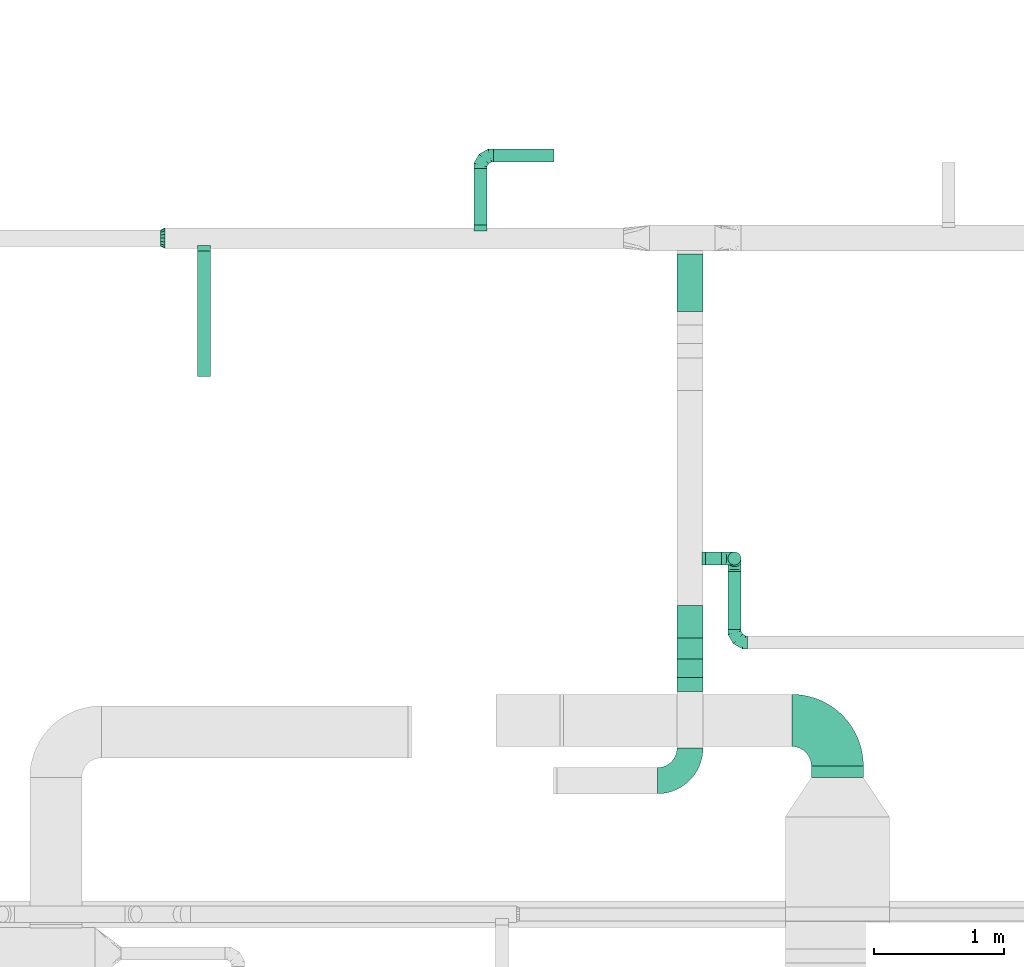
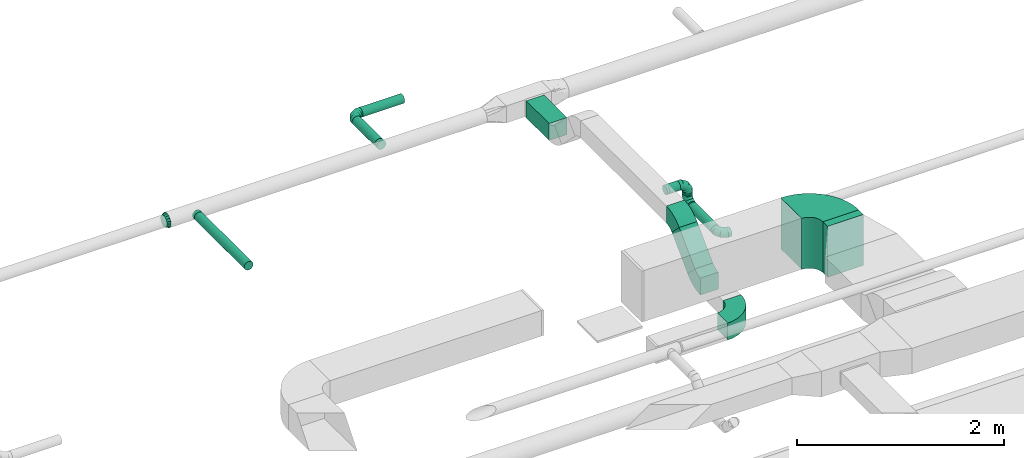
# One storey, part 40 of 60: 12 flow fittings, 9 flow segments.
"""IFC2X3 building model written with IfcOpenShell, lengths in millimetres."""

from ifc_helpers import new_model, entity, si_unit, converted_unit, derived_unit, direction, frame, frame_2d, origin, origin_2d_with_axis, place, context, subcontext, project, spatial, polyline, circle_curve, parameter, trimmed, segment, composite_curve, rectangle, circle, outline, extrude, faceted_brep, source, transform, mapped, material, type_object, type_shapes, element, save


model = new_model("IFC2X3")

# Units and contexts
model_context = context("Model", 3, precision=0.01, world=origin(), true_north=direction((6.12303176911189e-17, 1.0)))
body_context = subcontext(model_context, "Body", "Model", "MODEL_VIEW")
ifc_project = project(units=[si_unit("LENGTHUNIT", "METRE", prefix="MILLI"), si_unit("AREAUNIT", "SQUARE_METRE"), si_unit("VOLUMEUNIT", "CUBIC_METRE"), converted_unit("PLANEANGLEUNIT", "DEGREE", entity("IfcRatioMeasure", 0.0174532925199433), si_unit("PLANEANGLEUNIT", "RADIAN"), dimensions=[0, 0, 0, 0, 0, 0, 0]), si_unit("MASSUNIT", "GRAM", prefix="KILO"), derived_unit("MASSDENSITYUNIT", [(si_unit("MASSUNIT", "GRAM", prefix="KILO"), 1), (si_unit("LENGTHUNIT", "METRE"), -3)]), derived_unit("MOMENTOFINERTIAUNIT", [(si_unit("LENGTHUNIT", "METRE"), 4)]), si_unit("TIMEUNIT", "SECOND"), si_unit("FREQUENCYUNIT", "HERTZ"), si_unit("THERMODYNAMICTEMPERATUREUNIT", "DEGREE_CELSIUS"), derived_unit("THERMALTRANSMITTANCEUNIT", [(si_unit("MASSUNIT", "GRAM", prefix="KILO"), 1), (si_unit("THERMODYNAMICTEMPERATUREUNIT", "KELVIN"), -1), (si_unit("TIMEUNIT", "SECOND"), -3)]), derived_unit("VOLUMETRICFLOWRATEUNIT", [(si_unit("LENGTHUNIT", "METRE"), 3), (si_unit("TIMEUNIT", "SECOND"), -1)]), derived_unit("MASSFLOWRATEUNIT", [(si_unit("MASSUNIT", "GRAM", prefix="KILO"), 1), (si_unit("TIMEUNIT", "SECOND"), -1)]), derived_unit("ROTATIONALFREQUENCYUNIT", [(si_unit("TIMEUNIT", "SECOND"), -1)]), si_unit("ELECTRICCURRENTUNIT", "AMPERE"), si_unit("ELECTRICVOLTAGEUNIT", "VOLT"), si_unit("POWERUNIT", "WATT"), si_unit("FORCEUNIT", "NEWTON", prefix="KILO"), si_unit("ILLUMINANCEUNIT", "LUX"), si_unit("LUMINOUSFLUXUNIT", "LUMEN"), si_unit("LUMINOUSINTENSITYUNIT", "CANDELA"), derived_unit("USERDEFINED", [(si_unit("MASSUNIT", "GRAM", prefix="KILO"), -1), (si_unit("LENGTHUNIT", "METRE"), -2), (si_unit("TIMEUNIT", "SECOND"), 3), (si_unit("LUMINOUSFLUXUNIT", "LUMEN"), 1)]), derived_unit("LINEARVELOCITYUNIT", [(si_unit("LENGTHUNIT", "METRE"), 1), (si_unit("TIMEUNIT", "SECOND"), -1)]), si_unit("PRESSUREUNIT", "PASCAL"), derived_unit("USERDEFINED", [(si_unit("LENGTHUNIT", "METRE"), -2), (si_unit("MASSUNIT", "GRAM", prefix="KILO"), 1), (si_unit("TIMEUNIT", "SECOND"), -2)]), derived_unit("LINEARFORCEUNIT", [(si_unit("MASSUNIT", "GRAM", prefix="KILO"), 1), (si_unit("LENGTHUNIT", "METRE"), 1), (si_unit("TIMEUNIT", "SECOND"), -2), (si_unit("LENGTHUNIT", "METRE"), -1)]), derived_unit("PLANARFORCEUNIT", [(si_unit("MASSUNIT", "GRAM", prefix="KILO"), 1), (si_unit("LENGTHUNIT", "METRE"), 1), (si_unit("TIMEUNIT", "SECOND"), -2), (si_unit("LENGTHUNIT", "METRE"), -2)])], contexts=[model_context])

# Site, building, storey
site_placement = place(None, origin())
site = spatial("IfcSite", under=ifc_project, at=site_placement, CompositionType="ELEMENT")
building_placement = place(site_placement, origin())
building = spatial("IfcBuilding", under=site, at=building_placement, CompositionType="ELEMENT")
storey_placement = place(building_placement, frame((0.0, 0.0, 19800.0)))
storey = spatial("IfcBuildingStorey", under=building, at=storey_placement, CompositionType="ELEMENT", Elevation=19800.0)

# Flow segments
duct_segment_type_1 = type_object("IfcDuctSegmentType", PredefinedType="NOTDEFINED")
flow_segment_1_placement = place(storey_placement, frame((54721.8, 11333.78, 3050.0)))
element("IfcFlowSegment", 1, at=flow_segment_1_placement, inside=storey, type_object=duct_segment_type_1, context=body_context, shape_type="SweptSolid", body=[
    extrude(rectangle(XDim=90.0000000001701, YDim=399.999999999996, at=origin_2d_with_axis()), frame((200.0, 45.0, 0.0), z_axis=(0.0, 0.0, 1.0), x_axis=(0.0, -1.0, 0.0)), (0.0, 0.0, 1.0), 600.000000000002),
])
flow_segment_2_placement = place(storey_placement, frame((53690.46, 14914.29, 2850.0)))
element("IfcFlowSegment", 2, at=flow_segment_2_placement, inside=storey, type_object=duct_segment_type_1, context=body_context, shape_type="SweptSolid", body=[
    extrude(rectangle(XDim=441.446609406141, YDim=199.999999999998, at=origin_2d_with_axis()), frame((100.0, 220.72, 0.0), z_axis=(0.0, 0.0, 1.0), x_axis=(0.0, 1.0, 0.0)), (0.0, 0.0, 1.0), 199.999999999998),
])
flow_segment_3_placement = place(storey_placement, frame((53690.46, 12103.24, 2902.51)))
element("IfcFlowSegment", 3, at=flow_segment_3_placement, inside=storey, type_object=duct_segment_type_1, context=body_context, shape_type="SweptSolid", body=[
    extrude(rectangle(XDim=200.000000000001, YDim=199.999999999998, at=origin_2d_with_axis()), frame((100.0, 70.71, 70.71), z_axis=(0.0, 0.707106781186531, 0.707106781186564), x_axis=(0.0, -0.707106781186564, 0.707106781186531)), (0.0, 0.0, 1.0), 429.289321881351),
])
duct_segment_type_2 = type_object("IfcDuctSegmentType", PredefinedType="NOTDEFINED")
flow_segment_4_placement = place(storey_placement, frame((50007.13, 14415.73, 2898.4)))
element("IfcFlowSegment", 4, at=flow_segment_4_placement, inside=storey, type_object=duct_segment_type_2, context=body_context, shape_type="SweptSolid", body=[
    extrude(circle(Radius=50.0, at=origin_2d_with_axis()), frame((51.6, 0.0, 51.6), z_axis=(0.0, 1.0, 0.0), x_axis=(-1.0, 0.0, 0.0)), (0.0, 0.0, 1.0), 959.999999999834),
])
flow_segment_5_placement = place(storey_placement, frame((52129.46, 15575.73, 2898.4)))
element("IfcFlowSegment", 5, at=flow_segment_5_placement, inside=storey, type_object=duct_segment_type_2, context=body_context, shape_type="SweptSolid", body=[
    extrude(circle(Radius=50.0, at=origin_2d_with_axis()), frame((51.6, 0.0, 51.6), z_axis=(0.0, 1.0, 0.0), x_axis=(1.0, 0.0, 0.0)), (0.0, 0.0, 1.0), 435.00000000043),
])
flow_segment_6_placement = place(storey_placement, frame((52281.06, 16059.14, 2898.4)))
element("IfcFlowSegment", 6, at=flow_segment_6_placement, inside=storey, type_object=duct_segment_type_2, context=body_context, shape_type="SweptSolid", body=[
    extrude(circle(Radius=50.0, at=origin_2d_with_axis()), frame((0.0, 51.6, 51.6), z_axis=(1.0, 0.0, 0.0), x_axis=(0.0, -1.0, 0.0)), (0.0, 0.0, 1.0), 465.000000000007),
])
flow_segment_7_placement = place(storey_placement, frame((53910.46, 12965.51, 3298.4)))
element("IfcFlowSegment", 7, at=flow_segment_7_placement, inside=storey, type_object=duct_segment_type_2, context=body_context, shape_type="SweptSolid", body=[
    extrude(circle(Radius=50.0, at=origin_2d_with_axis()), frame((0.0, 51.6, 51.6), z_axis=(1.0, 0.0, 0.0), x_axis=(0.0, 1.0, 0.0)), (0.0, 0.0, 1.0), 121.250000000011),
])
flow_segment_8_placement = place(storey_placement, frame((54080.11, 12473.36, 3078.4)))
element("IfcFlowSegment", 8, at=flow_segment_8_placement, inside=storey, type_object=duct_segment_type_2, context=body_context, shape_type="SweptSolid", body=[
    extrude(circle(Radius=50.0, at=origin_2d_with_axis()), frame((51.6, 0.0, 51.6), z_axis=(0.0, 1.0, 0.0), x_axis=(-1.0, 0.0, 0.0)), (0.0, 0.0, 1.0), 443.750000000025),
])
flow_segment_9_placement = place(storey_placement, frame((54080.11, 12965.51, 3230.0)))
element("IfcFlowSegment", 9, at=flow_segment_9_placement, inside=storey, type_object=duct_segment_type_2, context=body_context, shape_type="SweptSolid", body=[
    extrude(circle(Radius=50.0, at=origin_2d_with_axis()), frame((51.6, 51.6, 0.0), z_axis=(0.0, 0.0, 1.0), x_axis=(0.0, 1.0, 0.0)), (0.0, 0.0, 1.0), 20.0000000000301),
])

# Flow fittings
ifc_material = material()
duct_fitting_type_1 = type_object("IfcDuctFittingType", PredefinedType="NOTDEFINED", material=ifc_material)
shared_shape_1 = source(origin(), body_context, "Body", "Brep", [
    faceted_brep([(-100.0, 0.0, -50.0), (-100.0, -12.94, -48.3), (-100.0, -25.0, -43.3), (-100.0, -35.36, -35.36), (-100.0, -43.3, -25.0), (-100.0, -48.3, -12.94), (-100.0, -50.0, 0.0), (-100.0, -48.3, 12.94), (-100.0, -43.3, 25.0), (-100.0, -35.36, 35.36), (-100.0, -25.0, 43.3), (-100.0, -12.94, 48.3), (-100.0, 0.0, 50.0), (-100.0, 12.94, 48.3), (-100.0, 25.0, 43.3), (-100.0, 35.36, 35.36), (-100.0, 43.3, 25.0), (-100.0, 48.3, 12.94), (-100.0, 50.0, 0.0), (-100.0, 48.3, -12.94), (-100.0, 43.3, -25.0), (-100.0, 35.36, -35.36), (-100.0, 25.0, -43.3), (-100.0, 12.94, -48.3), (-76.67, 12.94, 48.3), (-79.9, 25.0, 43.3), (-73.21, 0.0, 50.0), (-82.68, 35.36, 35.36), (-86.15, 48.3, 12.94), (-86.6, 50.0, 0.0), (-84.81, 43.3, 25.0), (-84.81, 43.3, -25.0), (-82.68, 35.36, -35.36), (-86.15, 48.3, -12.94), (-76.67, 12.94, -48.3), (-73.21, 0.0, -50.0), (-79.9, 25.0, -43.3), (-69.74, -12.94, -48.3), (-66.51, -25.0, -43.3), (-63.73, -35.36, -35.36), (-61.6, -43.3, -25.0), (-60.26, -48.3, -12.94), (-59.81, -50.0, 0.0), (-60.26, -48.3, 12.94), (-61.6, -43.3, 25.0), (-63.73, -35.36, 35.36), (-66.51, -25.0, 43.3), (-69.74, -12.94, 48.3), (-36.27, 36.27, 48.3), (-45.1, 45.1, 43.3), (-26.79, 26.79, 50.0), (-52.68, 52.68, 35.36), (-58.49, 58.49, 25.0), (-62.15, 62.15, 12.94), (-63.4, 63.4, 0.0), (-62.15, 62.15, -12.94), (-58.49, 58.49, -25.0), (-52.68, 52.68, -35.36), (-36.27, 36.27, -48.3), (-26.79, 26.79, -50.0), (-45.1, 45.1, -43.3), (-17.32, 17.32, -48.3), (-8.49, 8.49, -43.3), (-0.91, 0.91, -35.36), (4.9, -4.9, -25.0), (8.56, -8.56, -12.94), (9.81, -9.81, 0.0), (8.56, -8.56, 12.94), (4.9, -4.9, 25.0), (-0.91, 0.91, 35.36), (-8.49, 8.49, 43.3), (-17.32, 17.32, 48.3), (-12.94, 76.67, 48.3), (-25.0, 79.9, 43.3), (0.0, 73.21, 50.0), (-35.36, 82.68, 35.36), (-43.3, 84.81, 25.0), (-48.3, 86.15, 12.94), (-50.0, 86.6, 0.0), (-48.3, 86.15, -12.94), (-43.3, 84.81, -25.0), (-35.36, 82.68, -35.36), (-12.94, 76.67, -48.3), (0.0, 73.21, -50.0), (-25.0, 79.9, -43.3), (12.94, 69.74, -48.3), (25.0, 66.51, -43.3), (35.36, 63.73, -35.36), (43.3, 61.6, -25.0), (48.3, 60.26, -12.94), (50.0, 59.81, 0.0), (48.3, 60.26, 12.94), (43.3, 61.6, 25.0), (35.36, 63.73, 35.36), (25.0, 66.51, 43.3), (12.94, 69.74, 48.3), (-12.94, 100.0, -48.3), (-25.0, 100.0, -43.3), (-35.36, 100.0, -35.36), (-43.3, 100.0, -25.0), (-48.3, 100.0, -12.94), (-50.0, 100.0, 0.0), (-48.3, 100.0, 12.94), (-43.3, 100.0, 25.0), (-35.36, 100.0, 35.36), (-25.0, 100.0, 43.3), (-12.94, 100.0, 48.3), (0.0, 100.0, 50.0), (12.94, 100.0, 48.3), (25.0, 100.0, 43.3), (35.36, 100.0, 35.36), (43.3, 100.0, 25.0), (48.3, 100.0, 12.94), (50.0, 100.0, 0.0), (48.3, 100.0, -12.94), (43.3, 100.0, -25.0), (35.36, 100.0, -35.36), (25.0, 100.0, -43.3), (12.94, 100.0, -48.3), (0.0, 100.0, -50.0)], [[[0, 1, 2, 3, 4, 5, 6, 7, 8, 9, 10, 11, 12, 13, 14, 15, 16, 17, 18, 19, 20, 21, 22, 23]], [[24, 25, 14, 13]], [[26, 24, 13, 12]], [[14, 25, 27, 15]], [[28, 29, 18, 17]], [[30, 28, 17, 16]], [[15, 27, 30, 16]], [[20, 31, 32, 21]], [[33, 31, 20, 19]], [[18, 29, 33, 19]], [[34, 35, 0, 23]], [[36, 34, 23, 22]], [[32, 36, 22, 21]], [[2, 1, 37, 38]], [[3, 2, 38, 39]], [[0, 35, 37, 1]], [[5, 4, 40, 41]], [[6, 5, 41, 42]], [[3, 39, 40, 4]], [[6, 42, 43, 7]], [[7, 43, 44, 8]], [[8, 44, 45, 9]], [[10, 46, 47, 11]], [[11, 47, 26, 12]], [[10, 9, 45, 46]], [[48, 49, 25, 24]], [[50, 48, 24, 26]], [[27, 25, 49, 51]], [[52, 53, 28, 30]], [[51, 52, 30, 27]], [[29, 28, 53, 54]], [[55, 56, 31, 33]], [[54, 55, 33, 29]], [[57, 32, 31, 56]], [[58, 59, 35, 34]], [[60, 58, 34, 36]], [[57, 60, 36, 32]], [[37, 35, 59, 61]], [[38, 37, 61, 62]], [[39, 38, 62, 63]], [[41, 40, 64, 65]], [[42, 41, 65, 66]], [[63, 64, 40, 39]], [[43, 42, 66, 67]], [[44, 43, 67, 68]], [[68, 69, 45, 44]], [[46, 45, 69, 70]], [[47, 46, 70, 71]], [[26, 47, 71, 50]], [[72, 73, 49, 48]], [[74, 72, 48, 50]], [[51, 49, 73, 75]], [[76, 77, 53, 52]], [[75, 76, 52, 51]], [[54, 53, 77, 78]], [[79, 80, 56, 55]], [[78, 79, 55, 54]], [[81, 57, 56, 80]], [[82, 83, 59, 58]], [[84, 82, 58, 60]], [[81, 84, 60, 57]], [[61, 59, 83, 85]], [[62, 61, 85, 86]], [[63, 62, 86, 87]], [[65, 64, 88, 89]], [[66, 65, 89, 90]], [[87, 88, 64, 63]], [[67, 66, 90, 91]], [[68, 67, 91, 92]], [[92, 93, 69, 68]], [[70, 69, 93, 94]], [[71, 70, 94, 95]], [[50, 71, 95, 74]], [[96, 97, 98, 99, 100, 101, 102, 103, 104, 105, 106, 107, 108, 109, 110, 111, 112, 113, 114, 115, 116, 117, 118, 119]], [[72, 74, 107, 106]], [[73, 72, 106, 105]], [[75, 73, 105, 104]], [[77, 76, 103, 102]], [[78, 77, 102, 101]], [[75, 104, 103, 76]], [[78, 101, 100, 79]], [[79, 100, 99, 80]], [[80, 99, 98, 81]], [[96, 119, 83, 82]], [[97, 96, 82, 84]], [[84, 81, 98, 97]], [[83, 119, 118, 85]], [[85, 118, 117, 86]], [[86, 117, 116, 87]], [[88, 115, 114, 89]], [[89, 114, 113, 90]], [[87, 116, 115, 88]], [[91, 90, 113, 112]], [[92, 91, 112, 111]], [[93, 92, 111, 110]], [[95, 94, 109, 108]], [[74, 95, 108, 107]], [[110, 109, 94, 93]]]),
])
type_shapes(duct_fitting_type_1, [shared_shape_1])
for number, where, z_axis, x_axis in (
    (10, (52181.06, 16110.73, 2950.0), (0.0, 0.0, 1.0), (-1.0, 0.0, 0.0)),
    (11, (54131.71, 12373.36, 3130.0), (0.0, 0.0, 1.0), (0.0, -1.0, 0.0)),
    (12, (54131.71, 13017.11, 3130.0), (1.0, 0.0, 0.0), (0.0, 1.0, 0.0)),
    (13, (54131.71, 13017.11, 3350.0), (0.0, -1.0, 0.0), (0.0, 0.0, 1.0)),
):
    element("IfcFlowFitting", number, at=place(storey_placement, frame(where, z_axis=z_axis, x_axis=x_axis)), inside=storey, type_object=duct_fitting_type_1, material=ifc_material, context=body_context, shape_type="MappedRepresentation", body=[
        mapped(shared_shape_1, transform((0.0, 0.0, 0.0), scale=1.0)),
    ])
duct_fitting_type_2 = type_object("IfcDuctFittingType", PredefinedType="NOTDEFINED", material=ifc_material)
shared_shape_2 = source(origin(), body_context, "Body", "Brep", [
    faceted_brep([(35.0, -57.74, 23.92), (35.0, -60.12, 11.96), (35.0, -62.5, 0.0), (35.0, -60.12, -11.96), (35.0, -57.74, -23.92), (35.0, -50.97, -34.06), (35.0, -44.19, -44.19), (35.0, -34.06, -50.97), (35.0, -23.92, -57.74), (35.0, -11.96, -60.12), (35.0, 0.0, -62.5), (35.0, 11.96, -60.12), (35.0, 23.92, -57.74), (35.0, 34.06, -50.97), (35.0, 44.19, -44.19), (35.0, 50.97, -34.06), (35.0, 57.74, -23.92), (35.0, 60.12, -11.96), (35.0, 62.5, 0.0), (35.0, 60.12, 11.96), (35.0, 57.74, 23.92), (35.0, 50.97, 34.06), (35.0, 44.19, 44.19), (35.0, 34.06, 50.97), (35.0, 23.92, 57.74), (35.0, 11.96, 60.12), (35.0, 0.0, 62.5), (35.0, -11.96, 60.12), (35.0, -23.92, 57.74), (35.0, -34.06, 50.97), (35.0, -44.19, 44.19), (35.0, -50.97, 34.06), (0.0, -80.0, 0.0), (0.0, -77.45, 12.81), (0.0, -73.91, 30.61), (0.0, -65.24, 43.59), (0.0, -56.57, 56.57), (0.0, -43.59, 65.24), (0.0, -30.61, 73.91), (0.0, -12.81, 77.45), (0.0, 0.0, 80.0), (0.0, 12.81, 77.45), (0.0, 30.61, 73.91), (0.0, 43.59, 65.24), (0.0, 56.57, 56.57), (0.0, 65.24, 43.59), (0.0, 73.91, 30.61), (0.0, 77.45, 12.81), (0.0, 80.0, 0.0), (0.0, 77.45, -12.81), (0.0, 73.91, -30.61), (0.0, 65.24, -43.59), (0.0, 56.57, -56.57), (0.0, 43.59, -65.24), (0.0, 30.61, -73.91), (0.0, 12.81, -77.45), (0.0, 0.0, -80.0), (0.0, -12.81, -77.45), (0.0, -30.61, -73.91), (0.0, -43.59, -65.24), (0.0, -56.57, -56.57), (0.0, -65.24, -43.59), (0.0, -73.91, -30.61), (0.0, -77.45, -12.81)], [[[0, 1, 2, 3, 4, 5, 6, 7, 8, 9, 10, 11, 12, 13, 14, 15, 16, 17, 18, 19, 20, 21, 22, 23, 24, 25, 26, 27, 28, 29, 30, 31]], [[32, 33, 34, 35, 36, 37, 38, 39, 40, 41, 42, 43, 44, 45, 46, 47, 48, 49, 50, 51, 52, 53, 54, 55, 56, 57, 58, 59, 60, 61, 62, 63]], [[24, 23, 22, 44, 43, 42]], [[20, 46, 45, 44, 22, 21]], [[42, 41, 40, 26, 25, 24]], [[47, 46, 20, 19, 18, 48]], [[0, 31, 30, 36, 35, 34]], [[28, 38, 37, 36, 30, 29]], [[34, 33, 32, 2, 1, 0]], [[39, 38, 28, 27, 26, 40]], [[8, 7, 6, 60, 59, 58]], [[4, 62, 61, 60, 6, 5]], [[58, 57, 56, 10, 9, 8]], [[63, 62, 4, 3, 2, 32]], [[16, 15, 14, 52, 51, 50]], [[12, 54, 53, 52, 14, 13]], [[50, 49, 48, 18, 17, 16]], [[55, 54, 12, 11, 10, 56]]]),
])
type_shapes(duct_fitting_type_2, [shared_shape_2])
flow_fitting_1_placement = place(storey_placement, frame((49761.09, 15475.73, 2950.0), z_axis=(0.0, 0.0, 1.0), x_axis=(-1.0, 0.0, 0.0)))
element("IfcFlowFitting", 14, at=flow_fitting_1_placement, inside=storey, type_object=duct_fitting_type_2, material=ifc_material, context=body_context, shape_type="MappedRepresentation", body=[
    mapped(shared_shape_2, transform((0.0, 0.0, 0.0), scale=1.0)),
])
duct_fitting_type_3 = type_object("IfcDuctFittingType", PredefinedType="NOTDEFINED", material=ifc_material)
shared_shape_3 = source(origin(), body_context, "Body", "Brep", [
    faceted_brep([(20.0, 12.94, -48.3), (20.0, 25.0, -43.3), (20.0, 35.36, -35.36), (20.0, 43.3, -25.0), (20.0, 48.3, -12.94), (20.0, 50.0, 0.0), (20.0, 48.3, 12.94), (20.0, 43.3, 25.0), (20.0, 35.36, 35.36), (20.0, 25.0, 43.3), (20.0, 12.94, 48.3), (20.0, 0.0, 50.0), (20.0, -12.94, 48.3), (20.0, -25.0, 43.3), (20.0, -35.36, 35.36), (20.0, -43.3, 25.0), (20.0, -48.3, 12.94), (20.0, -50.0, 0.0), (20.0, -48.3, -12.94), (20.0, -43.3, -25.0), (20.0, -35.36, -35.36), (20.0, -25.0, -43.3), (20.0, -12.94, -48.3), (20.0, 0.0, -50.0), (0.0, 0.0, 50.0), (0.0, 12.94, 48.3), (-23.65, 12.94, 48.3), (-23.65, 0.0, 50.0), (0.0, 25.0, 43.3), (-23.65, 25.0, 43.3), (0.0, 35.36, 35.36), (-23.65, 35.36, 35.36), (0.0, 43.3, 25.0), (0.0, 48.3, 12.94), (-23.65, 48.3, 12.94), (-23.65, 43.3, 25.0), (0.0, 50.0, 0.0), (-23.65, 50.0, 0.0), (0.0, 48.3, -12.94), (-23.65, 48.3, -12.94), (0.0, 43.3, -25.0), (-23.65, 43.3, -25.0), (0.0, 35.36, -35.36), (-23.65, 35.36, -35.36), (0.0, 25.0, -43.3), (0.0, 12.94, -48.3), (-23.65, 12.94, -48.3), (-23.65, 25.0, -43.3), (0.0, 0.0, -50.0), (-23.65, 0.0, -50.0), (0.0, -12.94, -48.3), (-23.65, -12.94, -48.3), (0.0, -25.0, -43.3), (-23.65, -25.0, -43.3), (0.0, -35.36, -35.36), (-23.65, -35.36, -35.36), (0.0, -43.3, -25.0), (0.0, -48.3, -12.94), (-23.65, -48.3, -12.94), (-23.65, -43.3, -25.0), (0.0, -50.0, 0.0), (-23.65, -50.0, 0.0), (0.0, -48.3, 12.94), (-23.65, -48.3, 12.94), (0.0, -43.3, 25.0), (-23.65, -43.3, 25.0), (0.0, -35.36, 35.36), (-23.65, -35.36, 35.36), (0.0, -25.0, 43.3), (0.0, -12.94, 48.3), (-23.65, -12.94, 48.3), (-23.65, -25.0, 43.3)], [[[0, 1, 2, 3, 4, 5, 6, 7, 8, 9, 10, 11, 12, 13, 14, 15, 16, 17, 18, 19, 20, 21, 22, 23]], [[24, 11, 10, 25, 26, 27]], [[25, 10, 9, 28, 29, 26]], [[28, 9, 8, 30, 31, 29]], [[32, 7, 6, 33, 34, 35]], [[33, 6, 5, 36, 37, 34]], [[30, 8, 7, 32, 35, 31]], [[36, 5, 4, 38, 39, 37]], [[38, 4, 3, 40, 41, 39]], [[40, 3, 2, 42, 43, 41]], [[44, 1, 0, 45, 46, 47]], [[45, 0, 23, 48, 49, 46]], [[42, 2, 1, 44, 47, 43]], [[48, 23, 22, 50, 51, 49]], [[50, 22, 21, 52, 53, 51]], [[52, 21, 20, 54, 55, 53]], [[56, 19, 18, 57, 58, 59]], [[57, 18, 17, 60, 61, 58]], [[54, 20, 19, 56, 59, 55]], [[60, 17, 16, 62, 63, 61]], [[62, 16, 15, 64, 65, 63]], [[64, 15, 14, 66, 67, 65]], [[68, 13, 12, 69, 70, 71]], [[69, 12, 11, 24, 27, 70]], [[66, 14, 13, 68, 71, 67]], [[49, 51, 53, 55, 59, 58, 61, 63, 65, 67, 71, 70, 27, 26, 29, 31, 35, 34, 37, 39, 41, 43, 47, 46]]]),
])
type_shapes(duct_fitting_type_3, [shared_shape_3])
flow_fitting_2_placement = place(storey_placement, frame((52181.06, 15555.73, 2950.0), z_axis=(0.0, 0.0, -1.0), x_axis=(0.0, 1.0, 0.0)))
element("IfcFlowFitting", 15, at=flow_fitting_2_placement, inside=storey, type_object=duct_fitting_type_3, material=ifc_material, context=body_context, shape_type="MappedRepresentation", body=[
    mapped(shared_shape_3, transform((0.0, 0.0, 0.0), scale=1.0)),
])
duct_fitting_type_4 = type_object("IfcDuctFittingType", PredefinedType="NOTDEFINED", material=ifc_material)
shared_shape_4 = source(origin(), body_context, "Body", "Brep", [
    faceted_brep([(20.0, 0.0, -50.0), (20.0, 12.94, -48.3), (20.0, 25.0, -43.3), (20.0, 35.36, -35.36), (20.0, 43.3, -25.0), (20.0, 48.3, -12.94), (20.0, 50.0, 0.0), (20.0, 48.3, 12.94), (20.0, 43.3, 25.0), (20.0, 35.36, 35.36), (20.0, 25.0, 43.3), (20.0, 12.94, 48.3), (20.0, 0.0, 50.0), (20.0, -12.94, 48.3), (20.0, -25.0, 43.3), (20.0, -35.36, 35.36), (20.0, -43.3, 25.0), (20.0, -48.3, 12.94), (20.0, -50.0, 0.0), (20.0, -48.3, -12.94), (20.0, -43.3, -25.0), (20.0, -35.36, -35.36), (20.0, -25.0, -43.3), (20.0, -12.94, -48.3), (0.0, 0.0, 50.0), (-23.65, 0.0, 50.0), (-23.65, -12.94, 48.3), (0.0, -12.94, 48.3), (-23.65, -25.0, 43.3), (0.0, -25.0, 43.3), (0.0, -35.36, 35.36), (-23.65, -35.36, 35.36), (0.0, -43.3, 25.0), (-23.65, -43.3, 25.0), (-23.65, -48.3, 12.94), (0.0, -48.3, 12.94), (-23.65, -50.0, 0.0), (0.0, -50.0, 0.0), (-23.65, -48.3, -12.94), (0.0, -48.3, -12.94), (-23.65, -43.3, -25.0), (0.0, -43.3, -25.0), (0.0, -35.36, -35.36), (-23.65, -35.36, -35.36), (0.0, -25.0, -43.3), (-23.65, -25.0, -43.3), (-23.65, -12.94, -48.3), (0.0, -12.94, -48.3), (-23.65, 0.0, -50.0), (0.0, 0.0, -50.0), (-23.65, 12.94, -48.3), (0.0, 12.94, -48.3), (-23.65, 25.0, -43.3), (0.0, 25.0, -43.3), (0.0, 35.36, -35.36), (-23.65, 35.36, -35.36), (0.0, 43.3, -25.0), (-23.65, 43.3, -25.0), (-23.65, 48.3, -12.94), (0.0, 48.3, -12.94), (-23.65, 50.0, 0.0), (0.0, 50.0, 0.0), (-23.65, 48.3, 12.94), (0.0, 48.3, 12.94), (-23.65, 43.3, 25.0), (0.0, 43.3, 25.0), (0.0, 35.36, 35.36), (-23.65, 35.36, 35.36), (0.0, 25.0, 43.3), (-23.65, 25.0, 43.3), (-23.65, 12.94, 48.3), (0.0, 12.94, 48.3)], [[[0, 1, 2, 3, 4, 5, 6, 7, 8, 9, 10, 11, 12, 13, 14, 15, 16, 17, 18, 19, 20, 21, 22, 23]], [[13, 12, 24, 25, 26, 27]], [[14, 13, 27, 26, 28, 29]], [[30, 15, 14, 29, 28, 31]], [[17, 16, 32, 33, 34, 35]], [[18, 17, 35, 34, 36, 37]], [[32, 16, 15, 30, 31, 33]], [[19, 18, 37, 36, 38, 39]], [[20, 19, 39, 38, 40, 41]], [[42, 21, 20, 41, 40, 43]], [[23, 22, 44, 45, 46, 47]], [[0, 23, 47, 46, 48, 49]], [[44, 22, 21, 42, 43, 45]], [[1, 0, 49, 48, 50, 51]], [[2, 1, 51, 50, 52, 53]], [[54, 3, 2, 53, 52, 55]], [[5, 4, 56, 57, 58, 59]], [[6, 5, 59, 58, 60, 61]], [[56, 4, 3, 54, 55, 57]], [[7, 6, 61, 60, 62, 63]], [[8, 7, 63, 62, 64, 65]], [[66, 9, 8, 65, 64, 67]], [[11, 10, 68, 69, 70, 71]], [[12, 11, 71, 70, 25, 24]], [[68, 10, 9, 66, 67, 69]], [[46, 45, 43, 40, 38, 36, 34, 33, 31, 28, 26, 25, 70, 69, 67, 64, 62, 60, 58, 57, 55, 52, 50, 48]]]),
])
type_shapes(duct_fitting_type_4, [shared_shape_4])
flow_fitting_3_placement = place(storey_placement, frame((50058.73, 15395.73, 2950.0), z_axis=(0.0, 0.0, -1.0), x_axis=(0.0, -1.0, 0.0)))
element("IfcFlowFitting", 16, at=flow_fitting_3_placement, inside=storey, type_object=duct_fitting_type_4, material=ifc_material, context=body_context, shape_type="MappedRepresentation", body=[
    mapped(shared_shape_4, transform((0.0, 0.0, 0.0), scale=1.0)),
])
duct_fitting_type_5 = type_object("IfcDuctFittingType", PredefinedType="NOTDEFINED", material=ifc_material)
shared_shape_5 = source(origin(), body_context, "Body", "Brep", [
    faceted_brep([(20.0, 12.94, -48.3), (20.0, 25.0, -43.3), (20.0, 35.36, -35.36), (20.0, 43.3, -25.0), (20.0, 48.3, -12.94), (20.0, 50.0, 0.0), (20.0, 48.3, 12.94), (20.0, 43.3, 25.0), (20.0, 35.36, 35.36), (20.0, 25.0, 43.3), (20.0, 12.94, 48.3), (20.0, 0.0, 50.0), (20.0, -12.94, 48.3), (20.0, -25.0, 43.3), (20.0, -35.36, 35.36), (20.0, -43.3, 25.0), (20.0, -48.3, 12.94), (20.0, -50.0, 0.0), (20.0, -48.3, -12.94), (20.0, -43.3, -25.0), (20.0, -35.36, -35.36), (20.0, -25.0, -43.3), (20.0, -12.94, -48.3), (20.0, 0.0, -50.0), (0.0, 0.0, 50.0), (0.0, 12.94, 48.3), (-6.1, 12.94, 48.3), (-6.1, 0.0, 50.0), (0.0, 25.0, 43.3), (-6.1, 25.0, 43.3), (0.0, 35.36, 35.36), (-6.1, 35.36, 35.36), (0.0, 43.3, 25.0), (0.0, 48.3, 12.94), (-6.1, 48.3, 12.94), (-6.1, 43.3, 25.0), (0.0, 50.0, 0.0), (-6.1, 50.0, 0.0), (0.0, 48.3, -12.94), (-6.1, 48.3, -12.94), (0.0, 43.3, -25.0), (-6.1, 43.3, -25.0), (0.0, 35.36, -35.36), (-6.1, 35.36, -35.36), (0.0, 25.0, -43.3), (0.0, 12.94, -48.3), (-6.1, 12.94, -48.3), (-6.1, 25.0, -43.3), (0.0, 0.0, -50.0), (-6.1, 0.0, -50.0), (0.0, -12.94, -48.3), (-6.1, -12.94, -48.3), (0.0, -25.0, -43.3), (-6.1, -25.0, -43.3), (0.0, -35.36, -35.36), (-6.1, -35.36, -35.36), (0.0, -43.3, -25.0), (0.0, -48.3, -12.94), (-6.1, -48.3, -12.94), (-6.1, -43.3, -25.0), (0.0, -50.0, 0.0), (-6.1, -50.0, 0.0), (0.0, -48.3, 12.94), (-6.1, -48.3, 12.94), (0.0, -43.3, 25.0), (-6.1, -43.3, 25.0), (0.0, -35.36, 35.36), (-6.1, -35.36, 35.36), (0.0, -25.0, 43.3), (0.0, -12.94, 48.3), (-6.1, -12.94, 48.3), (-6.1, -25.0, 43.3)], [[[0, 1, 2, 3, 4, 5, 6, 7, 8, 9, 10, 11, 12, 13, 14, 15, 16, 17, 18, 19, 20, 21, 22, 23]], [[24, 11, 10, 25, 26, 27]], [[25, 10, 9, 28, 29, 26]], [[28, 9, 8, 30, 31, 29]], [[32, 7, 6, 33, 34, 35]], [[33, 6, 5, 36, 37, 34]], [[30, 8, 7, 32, 35, 31]], [[36, 5, 4, 38, 39, 37]], [[38, 4, 3, 40, 41, 39]], [[40, 3, 2, 42, 43, 41]], [[44, 1, 0, 45, 46, 47]], [[45, 0, 23, 48, 49, 46]], [[42, 2, 1, 44, 47, 43]], [[48, 23, 22, 50, 51, 49]], [[50, 22, 21, 52, 53, 51]], [[52, 21, 20, 54, 55, 53]], [[56, 19, 18, 57, 58, 59]], [[57, 18, 17, 60, 61, 58]], [[54, 20, 19, 56, 59, 55]], [[60, 17, 16, 62, 63, 61]], [[62, 16, 15, 64, 65, 63]], [[64, 15, 14, 66, 67, 65]], [[68, 13, 12, 69, 70, 71]], [[69, 12, 11, 24, 27, 70]], [[66, 14, 13, 68, 71, 67]], [[49, 51, 53, 55, 59, 58, 61, 63, 65, 67, 71, 70, 27, 26, 29, 31, 35, 34, 37, 39, 41, 43, 47, 46]]]),
])
type_shapes(duct_fitting_type_5, [shared_shape_5])
flow_fitting_4_placement = place(storey_placement, frame((53890.46, 13017.11, 3350.0), z_axis=(0.0, 0.0, -1.0), x_axis=(1.0, 0.0, 0.0)))
element("IfcFlowFitting", 17, at=flow_fitting_4_placement, inside=storey, type_object=duct_fitting_type_5, material=ifc_material, context=body_context, shape_type="MappedRepresentation", body=[
    mapped(shared_shape_5, transform((0.0, 0.0, 0.0), scale=1.0)),
])
duct_fitting_type_6 = type_object("IfcDuctFittingType", PredefinedType="NOTDEFINED", material=ifc_material)
shared_shape_6 = source(origin(), body_context, "Body", "SweptSolid", [
    extrude(outline(composite_curve([segment(polyline([(-225.0, -125.0), (-25.0, -125.0)]), True, "CONTINUOUS"), segment(trimmed(circle_curve(frame_2d((125.0, -125.0), x_axis=(0.0, 1.0)), 150.0), [parameter(0.0)], [parameter(90.0)], True, "PARAMETER"), False, "CONTINUOUS"), segment(polyline([(125.0, 25.0), (125.0, 225.0)]), True, "CONTINUOUS"), segment(trimmed(circle_curve(frame_2d((125.0, -125.0), x_axis=(0.0, 1.0)), 350.0), [parameter(0.0)], [parameter(90.0)], True, "PARAMETER"), True, "CONTINUOUS")], self_intersect=False)), frame((-125.0, 125.0, -100.0), z_axis=(0.0, 0.0, 1.0), x_axis=(-1.0, 0.0, 0.0)), (0.0, 0.0, 1.0), 200.0),
])
type_shapes(duct_fitting_type_6, [shared_shape_6])
flow_fitting_5_placement = place(storey_placement, frame((53790.46, 11310.73, 2900.0)))
element("IfcFlowFitting", 18, at=flow_fitting_5_placement, inside=storey, type_object=duct_fitting_type_6, material=ifc_material, context=body_context, shape_type="MappedRepresentation", body=[
    mapped(shared_shape_6, transform((0.0, 0.0, 0.0), scale=1.0)),
])
duct_fitting_type_7 = type_object("IfcDuctFittingType", PredefinedType="NOTDEFINED", material=ifc_material)
shared_shape_7 = source(origin(), body_context, "Body", "SweptSolid", [
    extrude(outline(composite_curve([segment(polyline([(-136.61, -88.39), (63.39, -88.39)]), True, "CONTINUOUS"), segment(trimmed(circle_curve(frame_2d((213.39, -88.39), x_axis=(-0.707106781186546, 0.707106781186546)), 150.0), [parameter(0.0)], [parameter(45.0)], True, "PARAMETER"), False, "CONTINUOUS"), segment(polyline([(107.32, 17.68), (-34.1, 159.1)]), True, "CONTINUOUS"), segment(trimmed(circle_curve(frame_2d((213.39, -88.39), x_axis=(-0.707106781186546, 0.707106781186546)), 350.0), [parameter(0.0)], [parameter(45.0)], True, "PARAMETER"), True, "CONTINUOUS")], self_intersect=False)), frame((-15.17, 36.61, -100.0), z_axis=(0.0, 0.0, 1.0), x_axis=(-0.707106781186547, 0.707106781186548, 0.0)), (0.0, 0.0, 1.0), 200.0),
])
type_shapes(duct_fitting_type_7, [shared_shape_7])
for number, where, z_axis, x_axis in (
    (19, (53790.46, 12100.73, 2900.0), (1.0, 0.0, 0.0), (0.0, 1.0, 0.0)),
    (20, (53790.46, 12550.73, 3350.0), (-1.0, 0.0, 0.0), (0.0, 0.707106781186517, 0.707106781186578)),
):
    element("IfcFlowFitting", number, at=place(storey_placement, frame(where, z_axis=z_axis, x_axis=x_axis)), inside=storey, type_object=duct_fitting_type_7, material=ifc_material, context=body_context, shape_type="MappedRepresentation", body=[
        mapped(shared_shape_7, transform((0.0, 0.0, 0.0), scale=1.0)),
    ])
duct_fitting_type_8 = type_object("IfcDuctFittingType", PredefinedType="NOTDEFINED", material=ifc_material)
shared_shape_8 = source(origin(), body_context, "Body", "SweptSolid", [
    extrude(outline(composite_curve([segment(polyline([(-375.0, -175.0), (25.0, -175.0)]), True, "CONTINUOUS"), segment(trimmed(circle_curve(frame_2d((175.0, -175.0), x_axis=(0.0, 1.0)), 150.0), [parameter(0.0)], [parameter(90.0000000000001)], True, "PARAMETER"), False, "CONTINUOUS"), segment(polyline([(175.0, -25.0), (175.0, 375.0)]), True, "CONTINUOUS"), segment(trimmed(circle_curve(frame_2d((175.0, -175.0), x_axis=(0.0, 1.0)), 550.0), [parameter(0.0)], [parameter(90.0)], True, "PARAMETER"), True, "CONTINUOUS")], self_intersect=False)), frame((-175.0, 175.0, -300.0), z_axis=(0.0, 0.0, 1.0), x_axis=(-1.0, 0.0, 0.0)), (0.0, 0.0, 1.0), 600.0),
])
type_shapes(duct_fitting_type_8, [shared_shape_8])
flow_fitting_6_placement = place(storey_placement, frame((54921.8, 11773.78, 3350.0), z_axis=(0.0, 0.0, 1.0), x_axis=(0.0, 1.0, 0.0)))
element("IfcFlowFitting", 21, at=flow_fitting_6_placement, inside=storey, type_object=duct_fitting_type_8, material=ifc_material, context=body_context, shape_type="MappedRepresentation", body=[
    mapped(shared_shape_8, transform((0.0, 0.0, 0.0), scale=1.0)),
])

save(model, "model.ifc")
